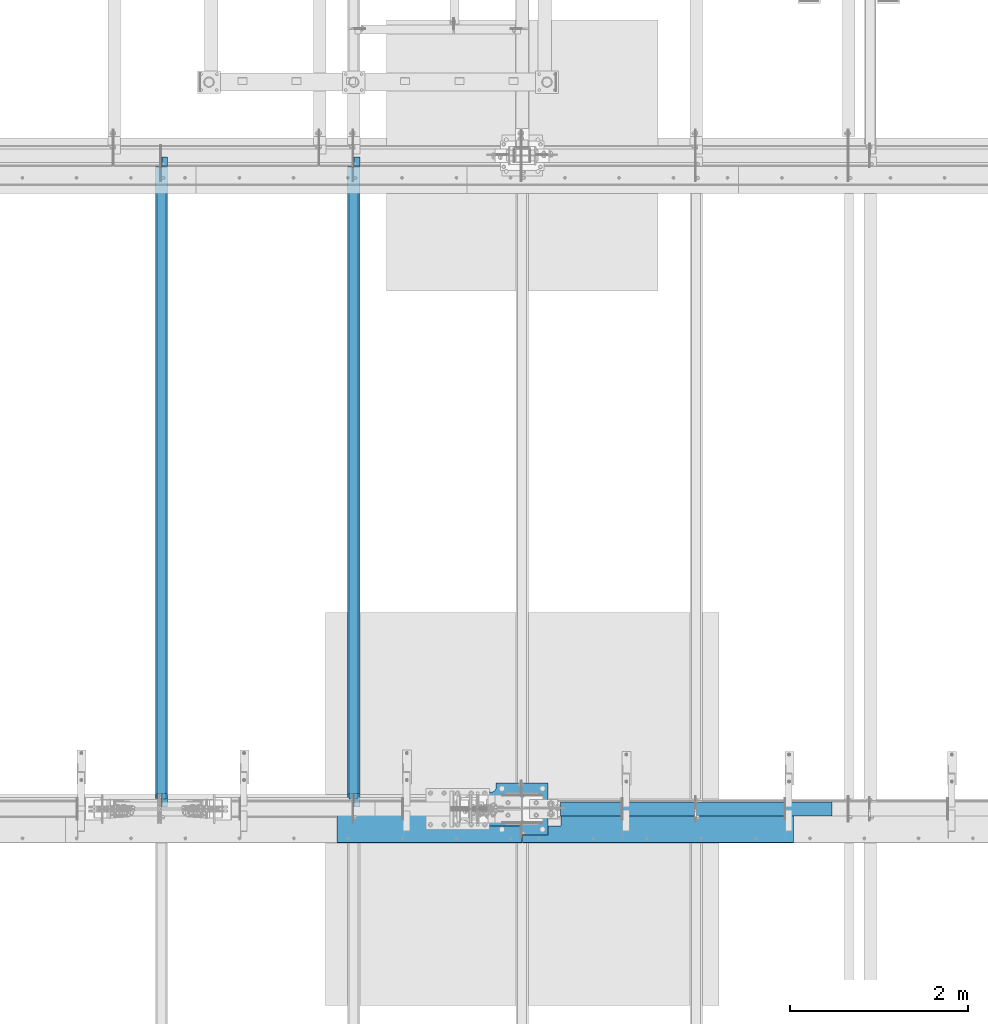
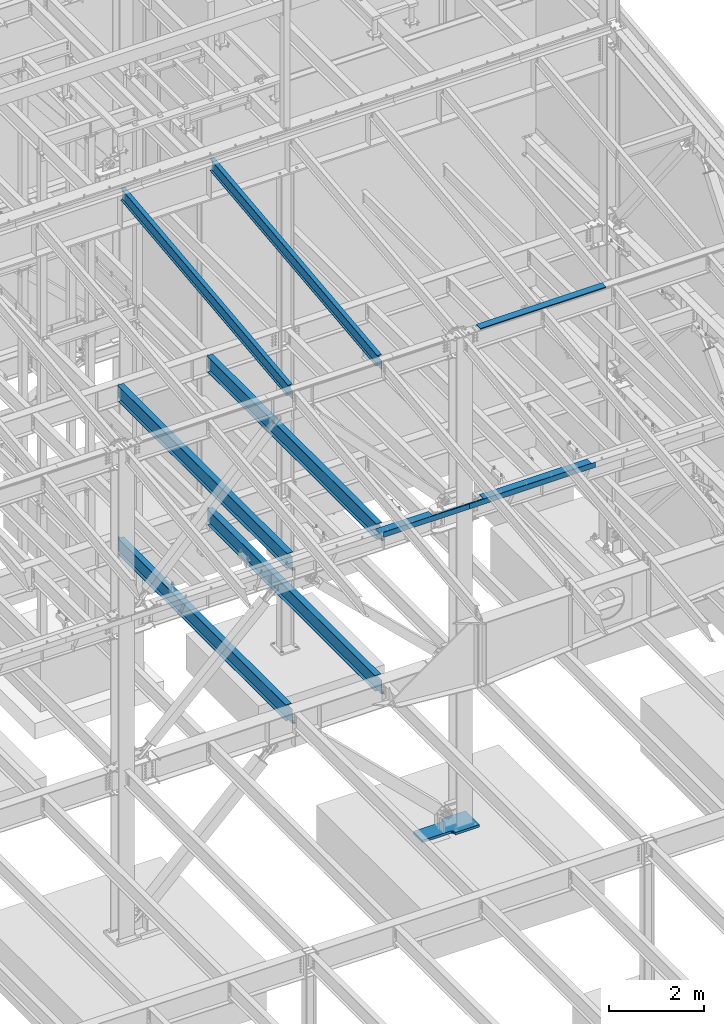
# One storey, part 738 of 1179: 10 beams, 10 elements without a shape of their own.
"""IFC2X3 building model written with IfcOpenShell, lengths in millimetres."""

import ifcopenshell
import ifcopenshell.guid

model = None  # the IFC model being written
_history = None  # IfcOwnerHistory: only IFC2X3 demands one
_inside = {}  # id of a spatial element -> (the spatial element, [elements in it])
_under = {}  # id of a project, library or spatial element -> (it, [spatial elements below it])
_declared = {}  # id of a project -> (the project, [libraries it declares])
_typed = {}  # id of a type object -> (the type object, [elements of that type])
_made_of = {}  # id of a material, layer set ... -> (it, [elements and type objects made of it])


def new_model(schema):
    """Start an empty IFC model of exactly this schema.

    Asked for "IFC4X3", IfcOpenShell would pick the latest addendum, in which some entities
    have other attributes; the version numbers below select the first issue.
    IFC2X3 requires an IfcOwnerHistory on every rooted entity: one is made here for all.
    """
    global model, _history
    if schema == "IFC4X3":
        model = ifcopenshell.file(schema_version=(4, 3, 0, 0))
    else:
        model = ifcopenshell.file(schema=schema)
    _inside.clear()
    _under.clear()
    _declared.clear()
    _typed.clear()
    _made_of.clear()
    _history = None
    if model.schema == "IFC2X3":
        org = make("IfcOrganization", Name="unknown")
        user = make(
            "IfcPersonAndOrganization",
            ThePerson=make("IfcPerson", FamilyName="unknown"),
            TheOrganization=org,
        )
        app = make(
            "IfcApplication",
            ApplicationDeveloper=org,
            Version="unknown",
            ApplicationFullName="unknown",
            ApplicationIdentifier="unknown",
        )
        _history = make(
            "IfcOwnerHistory",
            OwningUser=user,
            OwningApplication=app,
            ChangeAction="ADDED",
            CreationDate=0,
        )
    return model


def make(cls, **values):
    """One entity of the class cls with the attributes given. An attribute that is None is left unset."""
    return model.create_entity(
        cls, **{name: value for name, value in values.items() if value is not None}
    )


def rooted(cls, **values):
    """An entity with a GlobalId (a new one), such as an element, a storey or a relation."""
    return make(cls, GlobalId=ifcopenshell.guid.new(), OwnerHistory=_history, **values)


def si_unit(unit_type, name, prefix=None):
    """IfcSIUnit, for example si_unit("LENGTHUNIT", "METRE", prefix="MILLI")."""
    return make("IfcSIUnit", UnitType=unit_type, Prefix=prefix, Name=name)


def assignment(units):
    """IfcUnitAssignment: the units of a project."""
    return None if units is None else make("IfcUnitAssignment", Units=units)


def point(xyz):
    """IfcCartesianPoint."""
    return None if xyz is None else make("IfcCartesianPoint", Coordinates=xyz)


def direction(xyz):
    """IfcDirection."""
    return None if xyz is None else make("IfcDirection", DirectionRatios=xyz)


def frame(location, z_axis=None, x_axis=None):
    """IfcAxis2Placement3D, a coordinate frame: its origin and axes. An axis left out is left unset."""
    return make(
        "IfcAxis2Placement3D",
        Location=point(location),
        Axis=direction(z_axis),
        RefDirection=direction(x_axis),
    )


def origin_with_axes():
    """The frame at (0, 0, 0) with the z axis (0, 0, 1) and the x axis (1, 0, 0) written out."""
    return frame((0.0, 0.0, 0.0), z_axis=(0.0, 0.0, 1.0), x_axis=(1.0, 0.0, 0.0))


def place(relative_to, where):
    """IfcLocalPlacement: puts the frame where relative to a parent placement (None: the world)."""
    return make(
        "IfcLocalPlacement", PlacementRelTo=relative_to, RelativePlacement=where
    )


def context(
    kind, dimensions, precision=None, world=None, true_north=None, identifier=None
):
    """IfcGeometricRepresentationContext, for example the 3D "Model" context."""
    return make(
        "IfcGeometricRepresentationContext",
        ContextIdentifier=identifier,
        ContextType=kind,
        CoordinateSpaceDimension=dimensions,
        Precision=precision,
        WorldCoordinateSystem=world,
        TrueNorth=true_north,
    )


def subcontext(parent, identifier, kind, view, scale=None):
    """IfcGeometricRepresentationSubContext, for example "Body" below "Model"."""
    return make(
        "IfcGeometricRepresentationSubContext",
        ContextIdentifier=identifier,
        ContextType=kind,
        ParentContext=parent,
        TargetScale=scale,
        TargetView=view,
    )


def project(units=None, contexts=None):
    """IfcProject with its units and contexts."""
    return rooted(
        "IfcProject",
        Name="project",
        RepresentationContexts=contexts,
        UnitsInContext=assignment(units),
    )


def spatial(cls, under=None, at=None, **own):
    """A site, building, storey or space (cls), placed at a placement, below another one or the project."""
    s = rooted(cls, ObjectPlacement=at, **own)
    if under is not None:
        _under.setdefault(under.id(), (under, []))[1].append(s)
    return s


def faces_of(points, faces, orient=None, outer=None):
    """IfcFace entities. A face is a list of loops; a loop is a list of indices into points, from 0.

    orient and outer hold one flag for each loop. By default every Orientation is true, the
    first loop of a face is its IfcFaceOuterBound and the others are IfcFaceBound.
    """
    made = []
    for i, loops in enumerate(faces):
        bounds = []
        for j, loop in enumerate(loops):
            is_outer = j == 0 if outer is None else outer[i][j]
            bounds.append(
                make(
                    "IfcFaceOuterBound" if is_outer else "IfcFaceBound",
                    Bound=make("IfcPolyLoop", Polygon=[points[k] for k in loop]),
                    Orientation=True if orient is None else orient[i][j],
                )
            )
        made.append(make("IfcFace", Bounds=bounds))
    return made


def faceted_brep(points, faces, orient=None, outer=None, voids=None):
    """IfcFacetedBrep: a solid bounded by flat faces; with voids (closed shells), ...WithVoids."""
    shared = [point(p) for p in points]
    hull = make("IfcClosedShell", CfsFaces=faces_of(shared, faces, orient, outer))
    if voids is None:
        return make("IfcFacetedBrep", Outer=hull)
    return make(
        "IfcFacetedBrepWithVoids",
        Outer=hull,
        Voids=[
            make(cls, CfsFaces=faces_of(shared, fs, o, b)) for cls, fs, o, b in voids
        ],
    )


def shape(context_of_items, identifier, shape_type, items):
    """IfcShapeRepresentation: the items that make up one representation, for example the "Body"."""
    return make(
        "IfcShapeRepresentation",
        ContextOfItems=context_of_items,
        RepresentationIdentifier=identifier,
        RepresentationType=shape_type,
        Items=items,
    )


def material(Name=None, Category=None):
    """IfcMaterial."""
    return make("IfcMaterial", Name=Name, Category=Category)


def made_of(thing, what):
    """Note that an element or type object is made of a material, layer set ...; save() writes the relation."""
    if what is not None:
        _made_of.setdefault(what.id(), (what, []))[1].append(thing)
    return thing


def type_object(cls, material=None, **own):
    """A type object (cls), such as IfcWallType, which elements share."""
    return made_of(rooted(cls, **own), material)


def element(
    cls,
    number,
    at=None,
    inside=None,
    cuts=None,
    type_object=None,
    material=None,
    context=None,
    identifier="Body",
    shape_type=None,
    held_by="IfcProductDefinitionShape",
    body=None,
    shapes=None,
    **own,
):
    """One element of the class cls, such as IfcWall. Its Tag is "e" and its number.

    at: its placement. inside: the storey or other place that contains it. cuts: it is an
    opening in that element (IfcRelVoidsElement). A single representation is given by context,
    identifier, shape_type and body (its items); several are given by shapes. held_by: the class
    of the entity that holds the representations. save() writes the other relations.
    """
    e = rooted(cls, Tag="e%d" % number, ObjectPlacement=at, **own)
    if body is not None:
        shapes = [shape(context, identifier, shape_type, body)]
    if shapes is not None:
        e.Representation = make(held_by, Representations=shapes)
    if inside is not None:
        _inside.setdefault(inside.id(), (inside, []))[1].append(e)
    if cuts is not None:
        rooted(
            "IfcRelVoidsElement", RelatingBuildingElement=cuts, RelatedOpeningElement=e
        )
    if type_object is not None:
        _typed.setdefault(type_object.id(), (type_object, []))[1].append(e)
    return made_of(e, material)


def aggregate(whole, parts):
    """IfcRelAggregates: a whole, such as a stair, and the parts it consists of."""
    return rooted("IfcRelAggregates", RelatingObject=whole, RelatedObjects=parts)


def save(model, path):
    """Write the relations noted so far, then the file.

    IfcRelAggregates (storeys below a building ...), IfcRelContainedInSpatialStructure (elements
    in a storey), IfcRelDefinesByType, IfcRelAssociatesMaterial and IfcRelDeclares: one each for
    every whole, place, type object, material and project.
    """
    for whole, parts in _under.values():
        aggregate(whole, parts)
    for where, things in _inside.values():
        rooted(
            "IfcRelContainedInSpatialStructure",
            RelatedElements=things,
            RelatingStructure=where,
        )
    for kind, things in _typed.values():
        rooted("IfcRelDefinesByType", RelatedObjects=things, RelatingType=kind)
    for what, things in _made_of.values():
        rooted("IfcRelAssociatesMaterial", RelatedObjects=things, RelatingMaterial=what)
    for by, libraries in _declared.values():
        rooted("IfcRelDeclares", RelatingContext=by, RelatedDefinitions=libraries)
    model.write(path)


model = new_model("IFC2X3")

# Units and contexts
model_context = context("Model", 3, precision=1e-05, world=origin_with_axes())
body_context = subcontext(model_context, "Body", "Model", "MODEL_VIEW")
ifc_project = project(units=[si_unit("LENGTHUNIT", "METRE", prefix="MILLI"), si_unit("AREAUNIT", "SQUARE_METRE"), si_unit("VOLUMEUNIT", "CUBIC_METRE"), si_unit("MASSUNIT", "GRAM", prefix="KILO"), si_unit("TIMEUNIT", "SECOND"), si_unit("PLANEANGLEUNIT", "RADIAN"), si_unit("SOLIDANGLEUNIT", "STERADIAN"), si_unit("THERMODYNAMICTEMPERATUREUNIT", "DEGREE_CELSIUS"), si_unit("LUMINOUSINTENSITYUNIT", "LUMEN")], contexts=[model_context])

# Site, building, storey
site_placement = place(None, origin_with_axes())
site = spatial("IfcSite", under=ifc_project, at=site_placement, CompositionType="ELEMENT")
building_placement = place(site_placement, origin_with_axes())
building = spatial("IfcBuilding", under=site, at=building_placement, Name="Undefined", CompositionType="ELEMENT")
storey_placement = place(building_placement, origin_with_axes())
storey = spatial("IfcBuildingStorey", under=building, at=storey_placement, Name="Undefined", CompositionType="ELEMENT", Elevation=0.0)

# Assembly, beam
assembly_1_placement = place(storey_placement, origin_with_axes())
assembly_1 = element("IfcElementAssembly", 1, at=assembly_1_placement, inside=storey, Name="BEAM", AssemblyPlace="NOTDEFINED", PredefinedType="RIGID_FRAME")
ifc_material_1 = material(Name="STEEL/A36")
beam_type_1 = type_object("IfcBeamType", PredefinedType="NOTDEFINED")
beam_1_placement = place(assembly_1_placement, frame((18415.0000078262, 27124.0249999701, 12269.3906249899), z_axis=(-1.0, 0.0, 0.0), x_axis=(0.0, 0.0, 1.0)))
beam_1 = element("IfcBeam", 2, at=beam_1_placement, type_object=beam_type_1, material=ifc_material_1, Name="BENT_PLATE", context=body_context, shape_type="Brep", body=[
    faceted_brep([(-2.91038304567337e-11, -4.76250000000073, -1524.0), (-2.91038304567337e-11, -4.76250000000073, 1524.0), (2.91038304567337e-11, 4.76250000000073, 1524.0), (2.91038304567337e-11, 4.76250000000073, -1524.0), (43.0065173285329, 4.76249999974607, 1524.0), (43.0065173285329, 4.76249999974607, -1524.0), (32.344586885798, -4.7625000001899, -1524.0), (32.344586885798, -4.7625000001899, 1524.0), (25.4267482213236, -150.812499999749, 1524.0), (25.4267482213236, -150.812499999749, -1524.0), (16.9174425672263, -141.287499999748, -1524.0), (16.9174425672263, -141.287499999748, 1524.0), (8.54161044117063e-08, -150.812499999749, 1524.0), (8.54161044117063e-08, -150.812499999749, -1524.0), (8.54161044117063e-08, -141.287499999748, 1524.0), (8.54161044117063e-08, -141.287499999748, -1524.0)], [[[0, 1, 2, 3]], [[3, 2, 4, 5]], [[1, 0, 6, 7]], [[5, 4, 8, 9]], [[7, 6, 10, 11]], [[9, 8, 12, 13]], [[8, 4, 2, 1, 7, 11, 14, 12]], [[11, 10, 15, 14]], [[10, 6, 0, 3, 5, 9, 13, 15]], [[14, 15, 13, 12]]]),
])
aggregate(assembly_1, [beam_1])

assembly_2_placement = place(storey_placement, origin_with_axes())
assembly_2 = element("IfcElementAssembly", 3, at=assembly_2_placement, inside=storey, Name="BEAM", AssemblyPlace="NOTDEFINED", PredefinedType="RIGID_FRAME")
ifc_material_2 = material(Name="STEEL/A992")
beam_type_2 = type_object("IfcBeamType", Name="W16X31", PredefinedType="NOTDEFINED")
beam_2_placement = place(assembly_2_placement, frame((12407.9, 27051.0, 7812.0875), z_axis=(0.0, 0.0, 1.0), x_axis=(0.0, 1.0, 0.0)))
beam_2 = element("IfcBeam", 4, at=beam_2_placement, type_object=beam_type_2, material=ifc_material_2, Name="BEAM", ObjectType="W16X31", context=body_context, shape_type="Brep", body=[
    faceted_brep([(105.568750190734, -3.17499999999927, 157.1625), (105.568750190734, 3.17498369619716, 157.1625), (19.84375, 3.17499999999927, 157.1625), (19.84375, -3.17499999999927, 157.1625), (110.428829708781, -3.17499999999927, 158.129229922588), (110.428829708781, 3.17498323778818, 158.129229922588), (114.549006176934, -3.17499999999927, 160.882243823066), (114.549006176934, 3.17498193235224, 160.882243823066), (117.302020077412, -3.17499999999927, 165.00242029122), (117.302020077412, 3.17497997862665, 165.00242029122), (118.268749999999, -3.17499999999927, 169.862499809266), (118.268749999999, 3.17497767405257, 169.862499809266), (118.268749999999, -69.8500000000004, 201.6125), (118.268749999999, 69.8500000000004, 201.6125), (118.268749999999, 69.8500000000004, 190.5), (118.268749999999, 3.17499999999927, 190.5), (118.268749999999, -3.17499999999927, 190.5), (118.268749999999, -69.8500000000004, 190.5), (7196.1375, 3.17499999999927, -190.5), (7196.1375, 69.8500000000004, -190.5), (146.84375, 69.8500000000004, -190.5), (146.843749999996, 3.17536741349613, -190.499999999633), (19.84375, -3.17499999999927, -190.5), (19.84375, -69.8500000000004, -190.5), (7323.1375, -69.8500000000004, -190.5), (7323.1375, -3.17499999999927, -190.5), (19.84375, -69.8500000000004, -201.6125), (7323.1375, -69.8500000000004, -201.6125), (7196.1375, 69.8500000000004, -201.6125), (7196.1375, 3.17549991607484, -201.6125), (7323.1375, 3.17549991607484, -201.6125), (19.84375, 3.17537852599889, -201.6125), (146.843749999996, 3.17537852599889, -201.6125), (146.84375, 69.8500000000004, -201.6125), (19.84375, 3.17499999999927, -190.5), (7323.1375, 3.17499999999927, -190.5), (7323.1375, 3.17499999999927, 166.6875), (7323.1375, -3.17499999999927, 166.6875), (7235.82499980928, 3.17499999999927, 166.6875), (7235.82499980928, -3.17499999999927, 166.6875), (7230.96492029123, 3.17499999999927, 167.654229922588), (7230.96492029123, -3.17499999999927, 167.654229922588), (7226.84474382308, 3.17499999999927, 170.407243823066), (7226.84474382308, -3.17499999999927, 170.407243823066), (7224.0917299226, 3.17499999999927, 174.52742029122), (7224.0917299226, -3.17499999999927, 174.52742029122), (7223.12500000001, 3.17499999999927, 179.387499809265), (7223.12500000001, -3.17499999999927, 179.387499809265), (7223.12500000001, -69.8500000000004, 201.6125), (7223.12500000001, -69.8500000000004, 190.5), (7223.12500000001, -3.17499999999927, 190.5), (7223.12500000001, 3.17499999999927, 190.5), (7223.12500000001, 69.8500000000004, 190.5), (7223.12500000001, 69.8500000000004, 201.6125)], [[[0, 1, 2, 3]], [[4, 5, 1, 0]], [[6, 7, 5, 4]], [[8, 9, 7, 6]], [[10, 11, 9, 8]], [[12, 13, 14, 15, 11, 10, 16, 17]], [[18, 19, 20, 21]], [[22, 23, 24, 25]], [[23, 26, 27, 24]], [[28, 29, 30, 27, 26, 31, 32, 33]], [[21, 32, 31, 34]], [[20, 33, 32, 21]], [[19, 28, 33, 20]], [[18, 29, 28, 19]], [[35, 30, 29, 18]], [[25, 24, 27, 30, 35, 36, 37]], [[37, 36, 38, 39]], [[39, 38, 40, 41]], [[41, 40, 42, 43]], [[43, 42, 44, 45]], [[45, 44, 46, 47]], [[48, 49, 50, 47, 46, 51, 52, 53]], [[49, 48, 12, 17]], [[50, 49, 17, 16]], [[8, 6, 4, 0, 3, 22, 25, 37, 39, 41, 43, 45, 47, 50, 16, 10]], [[34, 31, 26, 23, 22, 3, 2]], [[51, 46, 44, 42, 40, 38, 36, 35, 18, 21, 34, 2, 1, 5, 7, 9, 11, 15]], [[52, 51, 15, 14]], [[53, 52, 14, 13]], [[48, 53, 13, 12]]]),
])
aggregate(assembly_2, [beam_2])

assembly_3_placement = place(storey_placement, origin_with_axes())
assembly_3 = element("IfcElementAssembly", 5, at=assembly_3_placement, inside=storey, Name="BEAM", AssemblyPlace="NOTDEFINED", PredefinedType="RIGID_FRAME")
beam_3_placement = place(assembly_3_placement, frame((14566.9, 27051.0, 7812.0875), z_axis=(0.0, 0.0, 1.0), x_axis=(0.0, 1.0, 0.0)))
beam_3 = element("IfcBeam", 6, at=beam_3_placement, type_object=beam_type_2, material=ifc_material_2, Name="BEAM", ObjectType="W16X31", context=body_context, shape_type="Brep", body=[
    faceted_brep([(105.568750190734, -3.17499999999927, 157.1625), (105.568750190734, 3.17498369619716, 157.1625), (19.84375, 3.17499999999927, 157.1625), (19.84375, -3.17499999999927, 157.1625), (110.428829708781, -3.17499999999927, 158.129229922588), (110.428829708781, 3.17498323778818, 158.129229922588), (114.549006176934, -3.17499999999927, 160.882243823066), (114.549006176934, 3.17498193235224, 160.882243823066), (117.302020077412, -3.17499999999927, 165.00242029122), (117.302020077412, 3.17497997862665, 165.00242029122), (118.268749999999, -3.17499999999927, 169.862499809266), (118.268749999999, 3.17497767405257, 169.862499809266), (118.268749999999, -69.8500000000004, 201.6125), (118.268749999999, 69.8500000000004, 201.6125), (118.268749999999, 69.8500000000004, 190.5), (118.268749999999, 3.17499999999927, 190.5), (118.268749999999, -3.17499999999927, 190.5), (118.268749999999, -69.8500000000004, 190.5), (7196.1375, 3.17499999999927, -190.5), (7196.1375, 69.8500000000004, -190.5), (146.84375, 69.8500000000004, -190.5), (146.843749999996, 3.17549991607484, -190.5), (19.84375, -3.17499999999927, -190.5), (19.84375, -69.8500000000004, -190.5), (7323.1375, -69.8500000000004, -190.5), (7323.1375, -3.17499999999927, -190.5), (19.84375, -69.8500000000004, -201.6125), (7323.1375, -69.8500000000004, -201.6125), (7196.1375, 69.8500000000004, -201.6125), (7196.1375, 3.17549991607484, -201.6125), (7323.1375, 3.17549991607484, -201.6125), (19.84375, 3.17549991607484, -201.6125), (146.843749999996, 3.17549991607484, -201.6125), (146.84375, 69.8500000000004, -201.6125), (19.84375, 3.17499999999927, -190.5), (7323.1375, 3.17499999999927, -190.5), (7323.1375, 3.17499999999927, 166.6875), (7323.1375, -3.17499999999927, 166.6875), (7235.82499980928, 3.17499999999927, 166.6875), (7235.82499980928, -3.17499999999927, 166.6875), (7230.96492029123, 3.17499999999927, 167.654229922588), (7230.96492029123, -3.17499999999927, 167.654229922588), (7226.84474382308, 3.17499999999927, 170.407243823066), (7226.84474382308, -3.17499999999927, 170.407243823066), (7224.0917299226, 3.17499999999927, 174.52742029122), (7224.0917299226, -3.17499999999927, 174.52742029122), (7223.12500000001, 3.17499999999927, 179.387499809265), (7223.12500000001, -3.17499999999927, 179.387499809265), (7223.12500000001, -69.8500000000004, 201.6125), (7223.12500000001, -69.8500000000004, 190.5), (7223.12500000001, -3.17499999999927, 190.5), (7223.12500000001, 3.17499999999927, 190.5), (7223.12500000001, 69.8500000000004, 190.5), (7223.12500000001, 69.8500000000004, 201.6125)], [[[0, 1, 2, 3]], [[4, 5, 1, 0]], [[6, 7, 5, 4]], [[8, 9, 7, 6]], [[10, 11, 9, 8]], [[12, 13, 14, 15, 11, 10, 16, 17]], [[18, 19, 20, 21]], [[22, 23, 24, 25]], [[23, 26, 27, 24]], [[28, 29, 30, 27, 26, 31, 32, 33]], [[21, 32, 31, 34]], [[20, 33, 32, 21]], [[19, 28, 33, 20]], [[18, 29, 28, 19]], [[35, 30, 29, 18]], [[25, 24, 27, 30, 35, 36, 37]], [[37, 36, 38, 39]], [[39, 38, 40, 41]], [[41, 40, 42, 43]], [[43, 42, 44, 45]], [[45, 44, 46, 47]], [[48, 49, 50, 47, 46, 51, 52, 53]], [[49, 48, 12, 17]], [[50, 49, 17, 16]], [[8, 6, 4, 0, 3, 22, 25, 37, 39, 41, 43, 45, 47, 50, 16, 10]], [[34, 31, 26, 23, 22, 3, 2]], [[51, 46, 44, 42, 40, 38, 36, 35, 18, 21, 34, 2, 1, 5, 7, 9, 11, 15]], [[52, 51, 15, 14]], [[53, 52, 14, 13]], [[48, 53, 13, 12]]]),
])
aggregate(assembly_3, [beam_3])

assembly_4_placement = place(storey_placement, origin_with_axes())
assembly_4 = element("IfcElementAssembly", 7, at=assembly_4_placement, inside=storey, Name="BEAM", AssemblyPlace="NOTDEFINED", PredefinedType="RIGID_FRAME")
beam_4_placement = place(assembly_4_placement, frame((14566.9, 27051.0, 3900.4875), z_axis=(0.0, 0.0, 1.0), x_axis=(0.0, 1.0, 0.0)))
beam_4 = element("IfcBeam", 8, at=beam_4_placement, type_object=beam_type_2, material=ifc_material_2, Name="BEAM", ObjectType="W16X31", context=body_context, shape_type="Brep", body=[
    faceted_brep([(163.512500190744, -3.17499999999927, 163.512499999999), (163.512500190744, 3.17497466870009, 163.512499999999), (20.6375000000007, 3.17499999999927, 163.512499999999), (20.6375000000007, -3.17499999999927, 163.512499999999), (168.37257970879, -3.17499999999927, 164.479229922587), (168.37257970879, 3.17497404500864, 164.479229922587), (172.492756176944, -3.17499999999927, 167.232243823065), (172.492756176944, 3.17497226888918, 167.232243823065), (175.245770077421, -3.17499999999927, 171.352420291219), (175.245770077421, 3.17496961073812, 171.352420291219), (176.212500000009, -3.17499999999927, 176.212499809265), (176.212500000009, 3.1749664752333, 176.212499809265), (176.212500000009, -69.8500000000004, 201.6125), (176.212500000009, 69.8500000000004, 201.6125), (176.212500000009, 69.8500000000004, 190.5), (176.212500000009, 3.17499999999927, 190.5), (176.212500000009, -3.17499999999927, 190.5), (176.212500000009, -69.8500000000004, 190.5), (7195.34375, 3.17499999999927, -190.5), (7195.34375, 69.8499999999985, -190.5), (176.212500000001, 69.8500000000004, -190.5), (176.212500000001, 3.17549991607848, -190.5), (20.6375000000007, -3.17499999999927, -190.5), (20.6375000000007, -69.8500000000004, -190.5), (7322.34375, -69.8499999999985, -190.5), (7322.34375, -3.17499999999927, -190.5), (20.6375000000007, -69.8500000000004, -201.6125), (7322.34375, -69.8499999999985, -201.6125), (7195.34375, 69.8499999999985, -201.6125), (7195.34375, 3.17549991607666, -201.6125), (7322.34375, 3.17549991607666, -201.6125), (20.6375000000007, 3.17549991607848, -201.6125), (176.212500000001, 3.17549991607848, -201.6125), (176.212500000001, 69.8500000000004, -201.6125), (20.6375000000007, 3.17499999999927, -190.5), (7322.34375, 3.17499999999927, -190.5), (7322.34375, 3.17499999999927, 169.8625), (7322.34375, -3.17499999999927, 169.8625), (7227.09374980925, 3.17499999999927, 169.8625), (7227.09374980925, -3.17499999999927, 169.8625), (7222.2336702912, 3.17499999999927, 170.829229922588), (7222.2336702912, -3.17499999999927, 170.829229922588), (7218.11349382305, 3.17499999999927, 173.582243823066), (7218.11349382305, -3.17499999999927, 173.582243823066), (7215.36047992257, 3.17499999999927, 177.70242029122), (7215.36047992257, -3.17499999999927, 177.70242029122), (7214.39374999998, 3.17499999999927, 182.562499809265), (7214.39374999998, -3.17499999999927, 182.562499809265), (7214.39374999998, -69.8499999999985, 201.6125), (7214.39374999998, -69.8499999999985, 190.5), (7214.39374999998, -3.17499999999927, 190.5), (7214.39374999998, 3.17499999999927, 190.5), (7214.39374999998, 69.8499999999985, 190.5), (7214.39374999998, 69.8499999999985, 201.6125)], [[[0, 1, 2, 3]], [[4, 5, 1, 0]], [[6, 7, 5, 4]], [[8, 9, 7, 6]], [[10, 11, 9, 8]], [[12, 13, 14, 15, 11, 10, 16, 17]], [[18, 19, 20, 21]], [[22, 23, 24, 25]], [[23, 26, 27, 24]], [[28, 29, 30, 27, 26, 31, 32, 33]], [[21, 32, 31, 34]], [[20, 33, 32, 21]], [[19, 28, 33, 20]], [[18, 29, 28, 19]], [[35, 30, 29, 18]], [[25, 24, 27, 30, 35, 36, 37]], [[37, 36, 38, 39]], [[39, 38, 40, 41]], [[41, 40, 42, 43]], [[43, 42, 44, 45]], [[45, 44, 46, 47]], [[48, 49, 50, 47, 46, 51, 52, 53]], [[49, 48, 12, 17]], [[50, 49, 17, 16]], [[8, 6, 4, 0, 3, 22, 25, 37, 39, 41, 43, 45, 47, 50, 16, 10]], [[34, 31, 26, 23, 22, 3, 2]], [[51, 46, 44, 42, 40, 38, 36, 35, 18, 21, 34, 2, 1, 5, 7, 9, 11, 15]], [[52, 51, 15, 14]], [[53, 52, 14, 13]], [[48, 53, 13, 12]]]),
])
aggregate(assembly_4, [beam_4])

assembly_5_placement = place(storey_placement, origin_with_axes())
assembly_5 = element("IfcElementAssembly", 9, at=assembly_5_placement, inside=storey, Name="BEAM", AssemblyPlace="NOTDEFINED", PredefinedType="RIGID_FRAME")
beam_5_placement = place(assembly_5_placement, frame((12407.9, 27051.0, 3900.4875), z_axis=(0.0, 0.0, 1.0), x_axis=(0.0, 1.0, 0.0)))
beam_5 = element("IfcBeam", 10, at=beam_5_placement, type_object=beam_type_2, material=ifc_material_2, Name="BEAM", ObjectType="W16X31", context=body_context, shape_type="Brep", body=[
    faceted_brep([(163.512500190744, -3.17499999999927, 163.512499999999), (163.512500190744, 3.17497466870009, 163.512499999999), (20.6375000000007, 3.17499999999927, 163.512499999999), (20.6375000000007, -3.17499999999927, 163.512499999999), (168.37257970879, -3.17499999999927, 164.479229922587), (168.37257970879, 3.17497404500864, 164.479229922587), (172.492756176944, -3.17499999999927, 167.232243823065), (172.492756176944, 3.17497226888918, 167.232243823065), (175.245770077421, -3.17499999999927, 171.352420291219), (175.245770077421, 3.17496961073812, 171.352420291219), (176.212500000009, -3.17499999999927, 176.212499809265), (176.212500000009, 3.1749664752333, 176.212499809265), (176.212500000009, -69.8500000000004, 201.6125), (176.212500000009, 69.8500000000004, 201.6125), (176.212500000009, 69.8500000000004, 190.5), (176.212500000009, 3.17499999999927, 190.5), (176.212500000009, -3.17499999999927, 190.5), (176.212500000009, -69.8500000000004, 190.5), (7195.34375, 3.17499999999927, -190.5), (7195.34375, 69.8499999999985, -190.5), (176.212500000001, 69.8500000000004, -190.5), (176.212500000001, 3.17549991607848, -190.5), (20.6375000000007, -3.17499999999927, -190.5), (20.6375000000007, -69.8500000000004, -190.5), (7322.34375, -69.8499999999985, -190.5), (7322.34375, -3.17499999999927, -190.5), (20.6375000000007, -69.8500000000004, -201.6125), (7322.34375, -69.8499999999985, -201.6125), (7195.34375, 69.8499999999985, -201.6125), (7195.34375, 3.17549991607666, -201.6125), (7322.34375, 3.17549991607666, -201.6125), (20.6375000000007, 3.17549991607848, -201.6125), (176.212500000001, 3.17549991607848, -201.6125), (176.212500000001, 69.8500000000004, -201.6125), (20.6375000000007, 3.17499999999927, -190.5), (7322.34375, 3.17499999999927, -190.5), (7322.34375, 3.17499999999927, 169.8625), (7322.34375, -3.17499999999927, 169.8625), (7227.09374980925, 3.17499999999927, 169.8625), (7227.09374980925, -3.17499999999927, 169.8625), (7222.2336702912, 3.17499999999927, 170.829229922588), (7222.2336702912, -3.17499999999927, 170.829229922588), (7218.11349382305, 3.17499999999927, 173.582243823066), (7218.11349382305, -3.17499999999927, 173.582243823066), (7215.36047992257, 3.17499999999927, 177.70242029122), (7215.36047992257, -3.17499999999927, 177.70242029122), (7214.39374999998, 3.17499999999927, 182.562499809265), (7214.39374999998, -3.17499999999927, 182.562499809265), (7214.39374999998, -69.8499999999985, 201.6125), (7214.39374999998, -69.8499999999985, 190.5), (7214.39374999998, -3.17499999999927, 190.5), (7214.39374999998, 3.17499999999927, 190.5), (7214.39374999998, 69.8499999999985, 190.5), (7214.39374999998, 69.8499999999985, 201.6125)], [[[0, 1, 2, 3]], [[4, 5, 1, 0]], [[6, 7, 5, 4]], [[8, 9, 7, 6]], [[10, 11, 9, 8]], [[12, 13, 14, 15, 11, 10, 16, 17]], [[18, 19, 20, 21]], [[22, 23, 24, 25]], [[23, 26, 27, 24]], [[28, 29, 30, 27, 26, 31, 32, 33]], [[21, 32, 31, 34]], [[20, 33, 32, 21]], [[19, 28, 33, 20]], [[18, 29, 28, 19]], [[35, 30, 29, 18]], [[25, 24, 27, 30, 35, 36, 37]], [[37, 36, 38, 39]], [[39, 38, 40, 41]], [[41, 40, 42, 43]], [[43, 42, 44, 45]], [[45, 44, 46, 47]], [[48, 49, 50, 47, 46, 51, 52, 53]], [[49, 48, 12, 17]], [[50, 49, 17, 16]], [[8, 6, 4, 0, 3, 22, 25, 37, 39, 41, 43, 45, 47, 50, 16, 10]], [[34, 31, 26, 23, 22, 3, 2]], [[51, 46, 44, 42, 40, 38, 36, 35, 18, 21, 34, 2, 1, 5, 7, 9, 11, 15]], [[52, 51, 15, 14]], [[53, 52, 14, 13]], [[48, 53, 13, 12]]]),
])
aggregate(assembly_5, [beam_5])

assembly_6_placement = place(storey_placement, origin_with_axes())
assembly_6 = element("IfcElementAssembly", 11, at=assembly_6_placement, inside=storey, Name="BEAM", AssemblyPlace="NOTDEFINED", PredefinedType="RIGID_FRAME")
beam_type_3 = type_object("IfcBeamType", PredefinedType="NOTDEFINED")
beam_6_placement = place(assembly_6_placement, frame((17986.375, 26673.175, 8147.05000610352), z_axis=(1.0, 0.0, 0.0), x_axis=(0.0, 0.0, -1.0)))
beam_6 = element("IfcBeam", 12, at=beam_6_placement, type_object=beam_type_3, material=ifc_material_1, Name="BENT_PLATE", context=body_context, shape_type="Brep", body=[
    faceted_brep([(133.350006103517, 188.912500000002, -1089.025), (127.000006103516, 188.912500000002, -1089.025), (127.000006103516, 346.074999237058, -1089.025), (133.350006103517, 346.074999237058, -1089.025), (133.350006103517, 188.912500000002, -1524.0), (127.000006103516, 188.912500000002, -1524.0), (0.0, 3.17499999999927, -1524.0), (6.00266503170133e-10, 3.17500000077416, 1524.00000000052), (127.000006103516, 3.17499999999927, 1524.0), (127.000006103516, 3.17499999999927, -1524.0), (0.0, -3.17499999999927, -1524.0), (6.00266503170133e-10, -3.17499999922438, 1524.00000000052), (133.350006103517, -3.17499999999927, -1524.0), (133.350006103517, -3.17499999999927, 1524.0), (133.350006103517, 346.074999237058, 1524.0), (127.000006103516, 346.074999237058, 1524.0)], [[[0, 1, 2, 3]], [[4, 5, 1, 0]], [[6, 7, 8, 9]], [[10, 11, 7, 6]], [[11, 10, 12, 13]], [[8, 7, 11, 13, 14, 15]], [[15, 14, 3, 2]], [[9, 8, 15, 2, 1, 5]], [[12, 10, 6, 9, 5, 4]], [[14, 13, 12, 4, 0, 3]]]),
])
aggregate(assembly_6, [beam_6])

assembly_7_placement = place(storey_placement, origin_with_axes())
assembly_7 = element("IfcElementAssembly", 13, at=assembly_7_placement, inside=storey, Name="BEAM", AssemblyPlace="NOTDEFINED", PredefinedType="RIGID_FRAME")
beam_7_placement = place(assembly_7_placement, frame((15417.8, 26673.175, 8147.05000610352), z_axis=(1.0, 0.0, 0.0), x_axis=(0.0, 0.0, -1.0)))
beam_7 = element("IfcBeam", 14, at=beam_7_placement, type_object=beam_type_3, material=ifc_material_1, Name="BENT_PLATE", context=body_context, shape_type="Brep", body=[
    faceted_brep([(133.350006103517, 346.074999237058, 253.991066524824), (127.000006103516, 346.074999237058, 253.991066524824), (127.000006103516, 188.912500000002, 253.991066524824), (133.350006103517, 188.912500000002, 253.991066524824), (133.350006103517, 188.912500000002, 1038.225), (127.000006103516, 188.912500000002, 1038.225), (0.0, -3.17500000000291, -1038.225), (0.0, -3.17499999999927, 1038.225), (0.0, 3.17499999999927, 1038.225), (0.0, 3.17500000000291, -1038.225), (127.000006103516, 3.17499999999927, 1038.225), (127.000006103516, 3.17499999999927, -1038.225), (133.350006103517, -3.17499999999927, -1038.225), (127.000006103516, 346.074999237058, -1038.225), (133.350006103517, 346.074999237058, -1038.225), (133.350006103517, -3.17499999999927, 1038.225)], [[[0, 1, 2, 3]], [[4, 3, 2, 5]], [[6, 7, 8, 9]], [[9, 8, 10, 11]], [[12, 6, 9, 11, 13, 14]], [[7, 6, 12, 15]], [[10, 8, 7, 15, 4, 5]], [[1, 13, 11, 10, 5, 2]], [[14, 13, 1, 0]], [[15, 12, 14, 0, 3, 4]]]),
])
aggregate(assembly_7, [beam_7])

assembly_8_placement = place(storey_placement, origin_with_axes())
assembly_8 = element("IfcElementAssembly", 15, at=assembly_8_placement, inside=storey, Name="BEAM", AssemblyPlace="NOTDEFINED", PredefinedType="RIGID_FRAME")
beam_type_4 = type_object("IfcBeamType", Name="W12X22", PredefinedType="NOTDEFINED")
beam_8_placement = place(assembly_8_placement, frame((14566.9, 27068.4779321143, 12149.0171463666), z_axis=(0.0, -0.112284087038017, 0.993676146336441), x_axis=(0.0, 0.993676146336441, 0.112284087038017)))
beam_8 = element("IfcBeam", 16, at=beam_8_placement, type_object=beam_type_4, material=ifc_material_2, Name="BEAM", ObjectType="W12X22", context=body_context, shape_type="Brep", body=[
    faceted_brep([(-15.5407998117698, -3.17499999999927, -144.462499999911), (-16.7964975778959, -3.17487472700668, -155.574999999904), (135.603493906594, -3.17489667232439, -155.574999999968), (135.603493906547, -3.17499999999927, -144.462499999972), (135.603487048622, -50.7999999999993, -144.462499999972), (135.603487048618, -50.7999999999993, -155.574999999964), (7139.32426989316, 3.17499999999927, -144.462500002814), (7139.32426989316, 50.7999999999993, -144.462500002814), (135.603501703274, 50.7999999999993, -144.462499999974), (135.603494845222, 3.17489668907729, -144.462500001895), (135.603494845269, 3.17510329651486, -155.574999999966), (-16.7964975778959, 3.17512524196718, -155.574999999904), (-15.5407998117698, 3.17499999999927, -144.462499999911), (135.603501703274, 50.7999999999993, -155.574999999966), (7138.06857212703, 50.7999999999993, -155.575000002807), (7142.71544233383, 3.17499999999927, -114.451772291532), (7168.54976507951, 3.17499999999927, 114.173235457372), (7171.97241181248, 3.17499999999927, 144.462499997011), (7171.97241181248, 50.7999999999993, 144.462499997011), (7173.22810957861, 50.7999999999993, 155.574999997003), (7173.22810957861, -50.7999999999993, 155.574999997003), (7171.97241181248, -50.7999999999993, 144.462499997011), (7171.97241181248, -3.17499999999927, 144.462499997011), (7139.32426989316, -3.17499999999927, -144.462500002814), (7139.32426989316, -50.7999999999993, -144.462500002814), (7138.06857212703, -50.7999999999993, -155.575000002807), (-14.7372101429282, -3.17499999999927, -137.351003558748), (10.2521606948103, -3.17499999999927, 83.7964659398294), (10.2521606948103, 3.17499999999927, 83.7964659398294), (-14.7371967980653, 3.17499999999927, -137.350885461223), (92.2801267643408, -3.17499999999927, 74.5274145334315), (92.2801267643408, 3.17499999999927, 74.5274145334315), (97.2180202374875, -3.17499999999927, 74.9423214058406), (97.2180202374875, 3.17499999999927, 74.9423214058406), (101.621260964999, -3.17499999999927, 77.215295396114), (101.621260964999, 3.17499999999927, 77.215295396114), (104.819495461597, -3.17499999999927, 81.0002968187928), (104.819495461597, 3.17499999999927, 81.0002968187928), (106.325821517235, -3.17499999999927, 85.7210935183975), (106.325821517235, 3.17499999999927, 85.7210935183975), (112.963522565431, 3.17499999999927, 144.462499999876), (112.963522565431, 50.7999999999993, 144.462499999876), (114.219220331557, 50.7999999999993, 155.57499999987), (114.219220331557, -50.7999999999993, 155.57499999987), (112.963522565431, -50.7999999999993, 144.462499999876), (112.963522565431, -3.17499999999927, 144.462499999876)], [[[0, 1, 2, 3]], [[4, 3, 2, 5]], [[6, 7, 8, 9]], [[9, 10, 11, 12]], [[8, 13, 10, 9]], [[7, 14, 13, 8]], [[6, 15, 16, 17, 18, 19, 20, 21, 22, 23, 24, 25, 14, 7]], [[25, 24, 4, 5]], [[1, 11, 10, 13, 14, 25, 5, 2]], [[26, 27, 28, 29, 12, 11, 1, 0]], [[30, 31, 28, 27]], [[32, 33, 31, 30]], [[34, 35, 33, 32]], [[36, 37, 35, 34]], [[38, 39, 37, 36]], [[17, 16, 15, 6, 9, 12, 29, 28, 31, 33, 35, 37, 39, 40]], [[18, 17, 40, 41]], [[19, 18, 41, 42]], [[20, 19, 42, 43]], [[21, 20, 43, 44]], [[22, 21, 44, 45]], [[43, 42, 41, 40, 39, 38, 45, 44]], [[36, 34, 32, 30, 27, 26, 0, 3, 23, 22, 45, 38]], [[24, 23, 3, 4]]]),
])
aggregate(assembly_8, [beam_8])

assembly_9_placement = place(storey_placement, origin_with_axes())
assembly_9 = element("IfcElementAssembly", 17, at=assembly_9_placement, inside=storey, Name="BEAM", AssemblyPlace="NOTDEFINED", PredefinedType="RIGID_FRAME")
beam_9_placement = place(assembly_9_placement, frame((12407.9, 27068.4779321143, 12149.0171463666), z_axis=(0.0, -0.112284087038017, 0.993676146336441), x_axis=(0.0, 0.993676146336441, 0.112284087038017)))
beam_9 = element("IfcBeam", 18, at=beam_9_placement, type_object=beam_type_4, material=ifc_material_2, Name="BEAM", ObjectType="W12X22", context=body_context, shape_type="Brep", body=[
    faceted_brep([(-15.5407998117698, -3.17499999999927, -144.462499999911), (-16.7964975778959, -3.17487472700668, -155.574999999904), (135.603493906594, -3.17489667232439, -155.574999999968), (135.603493906547, -3.17499999999927, -144.462499999972), (135.603487048622, -50.7999999999993, -144.462499999972), (135.603487048618, -50.7999999999993, -155.574999999964), (7139.32426989316, 3.17499999999927, -144.462500002814), (7139.32426989316, 50.7999999999993, -144.462500002814), (135.603501703274, 50.7999999999993, -144.462499999974), (135.603494845222, 3.17489668907729, -144.462500001895), (135.603494845269, 3.17510329651486, -155.574999999966), (-16.7964975778959, 3.17512524196718, -155.574999999904), (-15.5407998117698, 3.17499999999927, -144.462499999911), (135.603501703274, 50.7999999999993, -155.574999999966), (7138.06857212703, 50.7999999999993, -155.575000002807), (7142.71544233383, 3.17499999999927, -114.451772291532), (7168.54976507951, 3.17499999999927, 114.173235457372), (7171.97241181248, 3.17499999999927, 144.462499997011), (7171.97241181248, 50.7999999999993, 144.462499997011), (7173.22810957861, 50.7999999999993, 155.574999997003), (7173.22810957861, -50.7999999999993, 155.574999997003), (7171.97241181248, -50.7999999999993, 144.462499997011), (7171.97241181248, -3.17499999999927, 144.462499997011), (7139.32426989316, -3.17499999999927, -144.462500002814), (7139.32426989316, -50.7999999999993, -144.462500002814), (7138.06857212703, -50.7999999999993, -155.575000002807), (-14.7372101429282, -3.17499999999927, -137.351003558748), (10.2521606948103, -3.17499999999927, 83.7964659398294), (10.2521606948103, 3.17499999999927, 83.7964659398294), (-14.7371967980653, 3.17499999999927, -137.350885461223), (92.2801267643408, -3.17499999999927, 74.5274145334315), (92.2801267643408, 3.17499999999927, 74.5274145334315), (97.2180202374875, -3.17499999999927, 74.9423214058406), (97.2180202374875, 3.17499999999927, 74.9423214058406), (101.621260964999, -3.17499999999927, 77.215295396114), (101.621260964999, 3.17499999999927, 77.215295396114), (104.819495461597, -3.17499999999927, 81.0002968187928), (104.819495461597, 3.17499999999927, 81.0002968187928), (106.325821517235, -3.17499999999927, 85.7210935183975), (106.325821517235, 3.17499999999927, 85.7210935183975), (112.963522565431, 3.17499999999927, 144.462499999876), (112.963522565431, 50.7999999999993, 144.462499999876), (114.219220331557, 50.7999999999993, 155.57499999987), (114.219220331557, -50.7999999999993, 155.57499999987), (112.963522565431, -50.7999999999993, 144.462499999876), (112.963522565431, -3.17499999999927, 144.462499999876)], [[[0, 1, 2, 3]], [[4, 3, 2, 5]], [[6, 7, 8, 9]], [[9, 10, 11, 12]], [[8, 13, 10, 9]], [[7, 14, 13, 8]], [[6, 15, 16, 17, 18, 19, 20, 21, 22, 23, 24, 25, 14, 7]], [[25, 24, 4, 5]], [[1, 11, 10, 13, 14, 25, 5, 2]], [[26, 27, 28, 29, 12, 11, 1, 0]], [[30, 31, 28, 27]], [[32, 33, 31, 30]], [[34, 35, 33, 32]], [[36, 37, 35, 34]], [[38, 39, 37, 36]], [[17, 16, 15, 6, 9, 12, 29, 28, 31, 33, 35, 37, 39, 40]], [[18, 17, 40, 41]], [[19, 18, 41, 42]], [[20, 19, 42, 43]], [[21, 20, 43, 44]], [[22, 21, 44, 45]], [[43, 42, 41, 40, 39, 38, 45, 44]], [[36, 34, 32, 30, 27, 26, 0, 3, 23, 22, 45, 38]], [[24, 23, 3, 4]]]),
])
aggregate(assembly_9, [beam_9])

assembly_10_placement = place(storey_placement, origin_with_axes())
assembly_10 = element("IfcElementAssembly", 19, at=assembly_10_placement, inside=storey, Name="COLUMN", AssemblyPlace="NOTDEFINED", PredefinedType="RIGID_FRAME")
ifc_material_3 = material(Name="STEEL/A572-GR.50")
beam_type_5 = type_object("IfcBeamType", PredefinedType="NOTDEFINED")
beam_10_placement = place(assembly_10_placement, frame((16751.29949646, 27051.0, -247.65), z_axis=(0.0, -1.0, 0.0), x_axis=(-1.0, 0.0, 0.0)))
beam_10 = element("IfcBeam", 20, at=beam_10_placement, type_object=beam_type_5, material=ifc_material_3, context=body_context, shape_type="Brep", body=[
    faceted_brep([(584.199496459958, -31.75, 292.1), (584.199496459958, -31.75, 241.30000076336), (584.199496459958, 31.75, 241.30000076336), (584.199496459958, 31.75, 292.1), (588.066416150308, -31.75, 221.859682691178), (588.066416150308, 31.75, 221.859682691178), (599.078471752222, -31.75, 205.378976818563), (599.078471752222, 31.75, 205.378976818563), (615.559177624837, -31.75, 194.366921216651), (615.559177624837, 31.75, 194.366921216651), (634.999495697019, -31.75, 190.500001526299), (634.999495697019, 31.75, 190.500001526299), (1320.79949645996, -31.75, 190.500001526299), (1320.79949645996, 31.75, 190.500001526299), (0.0, -31.75, -292.1), (0.0, -31.75, 292.1), (0.0, 31.75, 292.1), (0.0, 31.75, -292.1), (584.199496459958, 31.75, -292.1), (584.199496459958, -31.75, -292.1), (584.199496459958, 31.75, -241.30000076336), (584.199496459958, -31.75, -241.30000076336), (588.066416150308, 31.75, -221.859682691178), (588.066416150308, -31.75, -221.859682691178), (599.078471752222, 31.75, -205.378976818563), (599.078471752222, -31.75, -205.378976818563), (615.559177624837, 31.75, -194.366921216651), (615.559177624837, -31.75, -194.366921216651), (634.999495697019, 31.75, -190.500001526299), (634.999495697019, -31.75, -190.500001526299), (1320.79949645996, -31.75, -190.500001526299), (1320.79949645996, 31.75, -190.500001526299)], [[[0, 1, 2, 3]], [[4, 5, 2, 1]], [[6, 7, 5, 4]], [[8, 9, 7, 6]], [[10, 11, 9, 8]], [[12, 13, 11, 10]], [[14, 15, 16, 17]], [[14, 17, 18, 19]], [[19, 18, 20, 21]], [[21, 20, 22, 23]], [[23, 22, 24, 25]], [[25, 24, 26, 27]], [[27, 26, 28, 29]], [[30, 29, 28, 31]], [[8, 6, 4, 1, 0, 15, 14, 19, 21, 23, 25, 27, 29, 30, 12, 10]], [[16, 15, 0, 3]], [[31, 28, 26, 24, 22, 20, 18, 17, 16, 3, 2, 5, 7, 9, 11, 13]], [[30, 31, 13, 12]]]),
])
aggregate(assembly_10, [beam_10])

save(model, "model.ifc")
